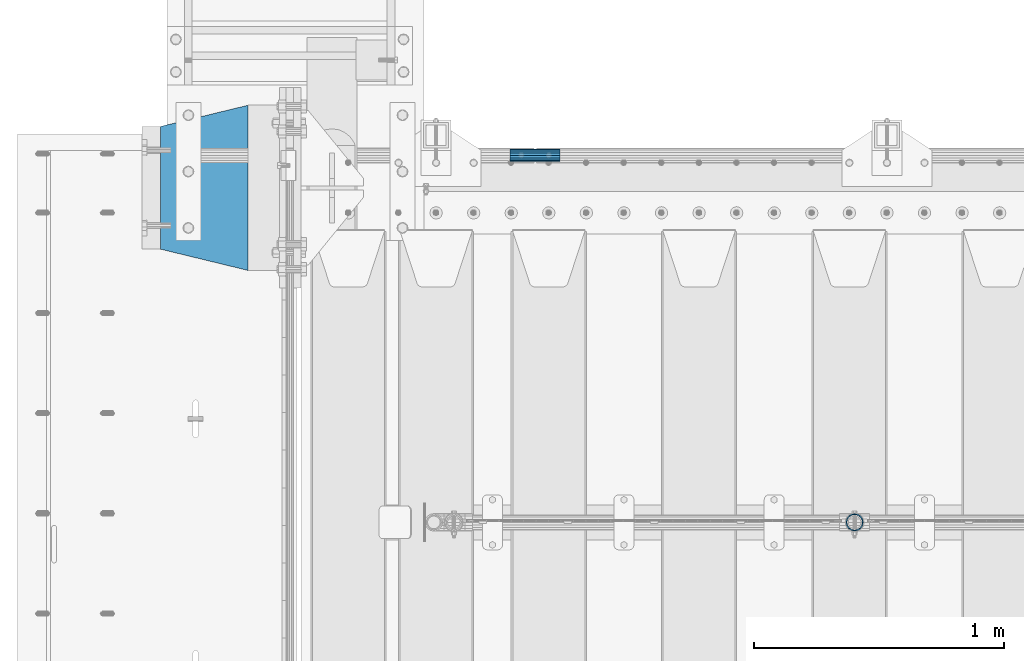
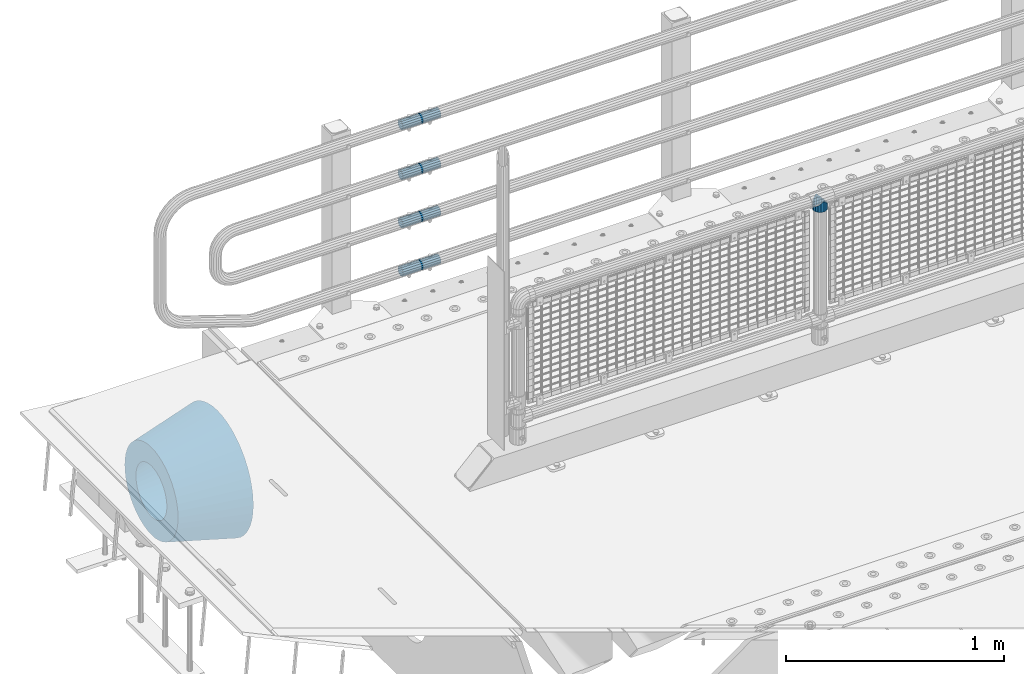
# One storey, part 148 of 247: 6 beams.
"""IFC2X3 building model written with IfcOpenShell, lengths in millimetres."""

from ifc_helpers import new_model, si_unit, frame, origin_with_axes, place, context, subcontext, project, spatial, faceted_brep, material, type_object, element, save


model = new_model("IFC2X3")

# Units and contexts
model_context = context("Model", 3, precision=1e-05, world=origin_with_axes())
body_context = subcontext(model_context, "Body", "Model", "MODEL_VIEW")
ifc_project = project(units=[si_unit("LENGTHUNIT", "METRE", prefix="MILLI"), si_unit("AREAUNIT", "SQUARE_METRE"), si_unit("VOLUMEUNIT", "CUBIC_METRE"), si_unit("MASSUNIT", "GRAM", prefix="KILO"), si_unit("TIMEUNIT", "SECOND"), si_unit("PLANEANGLEUNIT", "RADIAN"), si_unit("SOLIDANGLEUNIT", "STERADIAN"), si_unit("THERMODYNAMICTEMPERATUREUNIT", "DEGREE_CELSIUS"), si_unit("LUMINOUSINTENSITYUNIT", "LUMEN")], contexts=[model_context])

# Site, building, storey
site_placement = place(None, origin_with_axes())
site = spatial("IfcSite", under=ifc_project, at=site_placement, CompositionType="ELEMENT")
building_placement = place(site_placement, origin_with_axes())
building = spatial("IfcBuilding", under=site, at=building_placement, Name="Standard", CompositionType="ELEMENT")
storey_placement = place(building_placement, origin_with_axes())
storey = spatial("IfcBuildingStorey", under=building, at=storey_placement, Name="Undefined", CompositionType="ELEMENT", Elevation=0.0)

# Beams
ifc_material_1 = material(Name="Misc_Undefined")
beam_type_1 = type_object("IfcBeamType", PredefinedType="NOTDEFINED")
beam_1_placement = place(storey_placement, frame((2221.0, 7664.5, 969.849999999999), z_axis=(0.0, 1.0, 0.0), x_axis=(0.0, 0.0, -1.0)))
element("IfcBeam", 1, at=beam_1_placement, inside=storey, type_object=beam_type_1, material=ifc_material_1, context=body_context, shape_type="Brep", body=[
    faceted_brep([(0.0, 0.0, 35.1499999999996), (13.4513226476338, 13.4513226476329, 32.4743655677721), (13.4513226476338, -13.4513226476329, 32.4743655677721), (24.8548033587067, -16.3810424080045, -24.8548033587067), (24.8548033587067, -24.8548033587072, -24.8548033587067), (32.4743655677721, -32.4743655677717, -13.4513226476329), (32.4743655677721, -26.8123795176766, -13.4513226476329), (27.1226768591059, -21.4606908090117, -21.4606908090118), (0.0, 0.0, -35.1499999999996), (13.4513226476338, -13.4513226476329, -32.4743655677721), (13.4513226476338, 13.4513226476329, -32.4743655677721), (20.0882031229885, -11.6144421722805, -28.0397438117179), (16.6306603983739, 0.0, -30.3500000000004), (20.0882031229885, 11.6144421722805, -28.0397438117179), (24.8548033587067, 16.3810424080029, -24.8548033587067), (24.8548033587067, 24.8548033587072, -24.8548033587067), (27.1226768591059, 21.4606908090117, -21.4606908090118), (32.4743655677721, 26.8123795176755, -13.4513226476329), (32.4743655677721, 32.4743655677717, -13.4513226476329), (32.8397438117172, 28.0397438117175, -11.6144421722802), (35.1499999999996, 30.35, 0.0), (35.1499999999996, 35.15, 0.0), (32.8397438117172, 28.0397438117175, 11.6144421722802), (32.4743655677721, 26.8123795176755, 13.4513226476329), (32.4743655677721, 32.4743655677717, 13.4513226476329), (27.1226768591096, 21.4606908090117, 21.4606908090118), (24.8548033587067, 16.3810424080046, 24.8548033587067), (24.8548033587067, 24.8548033587072, 24.8548033587067), (20.0882031229812, 11.6144421722805, 28.0397438117179), (16.6306603983649, 0.0, 30.3500000000004), (20.0882031229812, -11.6144421722805, 28.0397438117179), (24.8548033587067, -16.3810424080045, 24.8548033587067), (24.8548033587067, -24.8548033587072, 24.8548033587067), (27.1226768591096, -21.4606908090117, 21.4606908090118), (32.4743655677721, -26.8123795176755, 13.4513226476329), (32.4743655677721, -32.4743655677717, 13.4513226476329), (32.8397438117172, -28.0397438117175, 11.6144421722802), (35.1499999999996, -30.35, 0.0), (35.1499999999996, -35.15, 0.0), (32.8397438117172, -28.0397438117175, -11.6144421722802), (60.1499999999996, -24.8548033587072, -24.8548033587067), (60.1499999999996, -32.4743655677717, -13.4513226476329), (60.1499999999996, -13.4513226476329, -32.4743655677721), (60.1499999999996, 0.0, -35.1499999999996), (60.1499999999996, 13.4513226476329, -32.4743655677721), (60.1499999999996, 24.8548033587072, -24.8548033587067), (60.1499999999996, 32.4743655677717, -13.4513226476329), (60.1499999999996, 35.15, 0.0), (60.1499999999996, 32.4743655677717, 13.4513226476329), (60.1499999999996, 24.8548033587072, 24.8548033587067), (60.1499999999996, 13.4513226476329, 32.4743655677721), (60.1499999999996, 0.0, 35.1499999999996), (60.1499999999996, -13.4513226476329, 32.4743655677721), (60.1499999999996, -24.8548033587072, 24.8548033587067), (60.1499999999996, -32.4743655677717, 13.4513226476329), (60.1499999999996, -35.15, 0.0), (60.1499999999996, -21.4606908090117, 21.4606908090118), (60.1499999999996, -11.6144421722805, 28.0397438117179), (60.1499999999996, 0.0, 30.3500000000004), (60.1499999999996, 11.6144421722805, 28.0397438117179), (60.1499999999996, 21.4606908090117, 21.4606908090118), (60.1499999999996, 28.0397438117175, 11.6144421722802), (60.1499999999996, 30.35, 0.0), (60.1499999999996, 28.0397438117175, -11.6144421722802), (60.1499999999996, 21.4606908090117, -21.4606908090118), (60.1499999999996, 11.6144421722805, -28.0397438117179), (60.1499999999996, 0.0, -30.3500000000004), (60.1499999999996, -11.6144421722805, -28.0397438117179), (60.1499999999996, -21.4606908090117, -21.4606908090118), (60.1499999999996, -28.0397438117175, -11.6144421722802), (60.1499999999996, -30.35, 0.0), (60.1499999999996, -28.0397438117175, 11.6144421722802)], [[[0, 1, 2]], [[3, 4, 5, 6, 7]], [[8, 9, 10]], [[10, 9, 4, 3, 11, 12, 13, 14, 15]], [[15, 14, 16, 17, 18]], [[18, 17, 19, 20, 21]], [[21, 20, 22, 23, 24]], [[24, 23, 25, 26, 27]], [[27, 26, 28, 29, 30, 31, 32, 2, 1]], [[33, 34, 35, 32, 31]], [[36, 37, 38, 35, 34]], [[6, 5, 38, 37, 39]], [[40, 41, 5, 4]], [[42, 40, 4, 9]], [[43, 42, 9, 8]], [[44, 43, 8, 10]], [[45, 44, 10, 15]], [[46, 45, 15, 18]], [[47, 46, 18, 21]], [[48, 47, 21, 24]], [[49, 48, 24, 27]], [[50, 49, 27, 1]], [[51, 50, 1, 0]], [[52, 51, 0, 2]], [[53, 52, 2, 32]], [[54, 53, 32, 35]], [[55, 54, 35, 38]], [[41, 55, 38, 5]], [[40, 42, 43, 44, 45, 46, 47, 48, 49, 50, 51, 52, 53, 54, 55, 41], [56, 57, 58, 59, 60, 61, 62, 63, 64, 65, 66, 67, 68, 69, 70, 71]], [[71, 70, 37, 36]], [[56, 71, 36, 34, 33]], [[57, 56, 33, 31, 30]], [[58, 57, 30, 29]], [[59, 58, 29, 28]], [[25, 60, 59, 28, 26]], [[22, 61, 60, 25, 23]], [[62, 61, 22, 20]], [[63, 62, 20, 19]], [[64, 63, 19, 17, 16]], [[65, 64, 16, 14, 13]], [[66, 65, 13, 12]], [[67, 66, 12, 11]], [[7, 68, 67, 11, 3]], [[39, 69, 68, 7, 6]], [[70, 69, 39, 37]]]),
])
ifc_material_2 = material()
beam_type_2 = type_object("IfcBeamType", PredefinedType="NOTDEFINED")
beam_2_placement = place(storey_placement, frame((844.997502999948, 9129.8500000004, 149.849999999725), z_axis=(0.0, 0.0, 1.0), x_axis=(1.0, 0.0, 0.0)))
element("IfcBeam", 2, at=beam_2_placement, inside=storey, type_object=beam_type_2, material=ifc_material_2, context=body_context, shape_type="Brep", body=[
    faceted_brep([(0.0, -21.8999999999996, 0.0), (0.0, -20.232961761998, 8.38076716879547), (200.0, -20.232961761998, 8.38076716879547), (200.0, -21.8999999999996, 0.0), (0.0, -15.4856385079856, 15.4856385079854), (200.0, -15.4856385079856, 15.4856385079854), (0.0, -8.3807671687955, 20.2329617619972), (200.0, -8.3807671687955, 20.2329617619972), (0.0, 0.0, 21.9), (200.0, 0.0, 21.9), (0.0, 8.3807671687955, 20.2329617619972), (200.0, 8.3807671687955, 20.2329617619972), (0.0, 15.4856385079856, 15.4856385079854), (200.0, 15.4856385079856, 15.4856385079854), (0.0, 20.232961761998, 8.38076716879547), (200.0, 20.232961761998, 8.38076716879547), (0.0, 21.8999999999996, 0.0), (200.0, 21.8999999999996, 0.0), (0.0, 20.232961761998, -8.38076716879547), (200.0, 20.232961761998, -8.38076716879547), (0.0, 15.4856385079856, -15.4856385079854), (200.0, 15.4856385079856, -15.4856385079854), (0.0, 8.3807671687955, -20.2329617619972), (200.0, 8.3807671687955, -20.2329617619972), (0.0, 0.0, -21.9), (200.0, 0.0, -21.9), (0.0, -8.3807671687955, -20.2329617619972), (200.0, -8.3807671687955, -20.2329617619972), (0.0, -15.4856385079856, -15.4856385079854), (200.0, -15.4856385079856, -15.4856385079854), (0.0, -20.232961761998, -8.38076716879547), (200.0, -20.232961761998, -8.38076716879547), (0.0, -25.5, 0.0), (0.0, -23.5589280790373, -9.7584275253098), (200.0, -23.5589280790373, -9.7584275253098), (200.0, -25.5, 0.0), (0.0, -18.0312229202573, -18.031222920257), (200.0, -18.0312229202573, -18.031222920257), (0.0, -9.75842752531025, -23.5589280790378), (200.0, -9.75842752531025, -23.5589280790378), (0.0, 0.0, -25.5), (200.0, 0.0, -25.5), (0.0, 9.75842752531025, -23.5589280790378), (200.0, 9.75842752531025, -23.5589280790378), (0.0, 18.0312229202573, -18.031222920257), (200.0, 18.0312229202573, -18.031222920257), (0.0, 23.5589280790373, -9.7584275253098), (200.0, 23.5589280790373, -9.7584275253098), (0.0, 25.5, 0.0), (200.0, 25.5, 0.0), (0.0, 23.5589280790373, 9.7584275253098), (200.0, 23.5589280790373, 9.7584275253098), (0.0, 18.0312229202573, 18.031222920257), (200.0, 18.0312229202573, 18.031222920257), (0.0, 9.75842752531025, 23.5589280790378), (200.0, 9.75842752531025, 23.5589280790378), (0.0, 0.0, 25.5), (200.0, 0.0, 25.5), (0.0, -9.75842752531025, 23.5589280790378), (200.0, -9.75842752531025, 23.5589280790378), (0.0, -18.0312229202573, 18.031222920257), (200.0, -18.0312229202573, 18.031222920257), (0.0, -23.5589280790373, 9.7584275253098), (200.0, -23.5589280790373, 9.7584275253098)], [[[0, 1, 2, 3]], [[1, 4, 5, 2]], [[4, 6, 7, 5]], [[6, 8, 9, 7]], [[8, 10, 11, 9]], [[10, 12, 13, 11]], [[12, 14, 15, 13]], [[14, 16, 17, 15]], [[16, 18, 19, 17]], [[18, 20, 21, 19]], [[20, 22, 23, 21]], [[22, 24, 25, 23]], [[24, 26, 27, 25]], [[26, 28, 29, 27]], [[28, 30, 31, 29]], [[30, 0, 3, 31]], [[32, 33, 34, 35]], [[33, 36, 37, 34]], [[36, 38, 39, 37]], [[38, 40, 41, 39]], [[40, 42, 43, 41]], [[42, 44, 45, 43]], [[44, 46, 47, 45]], [[46, 48, 49, 47]], [[48, 50, 51, 49]], [[50, 52, 53, 51]], [[52, 54, 55, 53]], [[54, 56, 57, 55]], [[56, 58, 59, 57]], [[58, 60, 61, 59]], [[60, 62, 63, 61]], [[62, 32, 35, 63]], [[37, 39, 41, 43, 45, 47, 49, 51, 53, 55, 57, 59, 61, 63, 35, 34], [5, 7, 9, 11, 13, 15, 17, 19, 21, 23, 25, 27, 29, 31, 3, 2]], [[62, 60, 58, 56, 54, 52, 50, 48, 46, 44, 42, 40, 38, 36, 33, 32], [30, 28, 26, 24, 22, 20, 18, 16, 14, 12, 10, 8, 6, 4, 1, 0]]]),
])
beam_3_placement = place(storey_placement, frame((844.997502999948, 9129.8500000004, 420.149999999724), z_axis=(0.0, 0.0, 1.0), x_axis=(1.0, 0.0, 0.0)))
element("IfcBeam", 3, at=beam_3_placement, inside=storey, type_object=beam_type_2, material=ifc_material_2, context=body_context, shape_type="Brep", body=[
    faceted_brep([(0.0, -21.8999999999996, 0.0), (0.0, -20.232961761998, 8.38076716879547), (200.0, -20.232961761998, 8.38076716879547), (200.0, -21.8999999999996, 0.0), (0.0, -15.4856385079856, 15.4856385079854), (200.0, -15.4856385079856, 15.4856385079854), (0.0, -8.3807671687955, 20.2329617619972), (200.0, -8.3807671687955, 20.2329617619972), (0.0, 0.0, 21.9), (200.0, 0.0, 21.9), (0.0, 8.3807671687955, 20.2329617619972), (200.0, 8.3807671687955, 20.2329617619972), (0.0, 15.4856385079856, 15.4856385079854), (200.0, 15.4856385079856, 15.4856385079854), (0.0, 20.232961761998, 8.38076716879547), (200.0, 20.232961761998, 8.38076716879547), (0.0, 21.8999999999996, 0.0), (200.0, 21.8999999999996, 0.0), (0.0, 20.232961761998, -8.38076716879547), (200.0, 20.232961761998, -8.38076716879547), (0.0, 15.4856385079856, -15.4856385079854), (200.0, 15.4856385079856, -15.4856385079854), (0.0, 8.3807671687955, -20.2329617619972), (200.0, 8.3807671687955, -20.2329617619972), (0.0, 0.0, -21.9), (200.0, 0.0, -21.9), (0.0, -8.3807671687955, -20.2329617619972), (200.0, -8.3807671687955, -20.2329617619972), (0.0, -15.4856385079856, -15.4856385079854), (200.0, -15.4856385079856, -15.4856385079854), (0.0, -20.232961761998, -8.38076716879547), (200.0, -20.232961761998, -8.38076716879547), (0.0, -25.5, 0.0), (0.0, -23.5589280790373, -9.7584275253098), (200.0, -23.5589280790373, -9.7584275253098), (200.0, -25.5, 0.0), (0.0, -18.0312229202573, -18.031222920257), (200.0, -18.0312229202573, -18.031222920257), (0.0, -9.75842752531025, -23.5589280790378), (200.0, -9.75842752531025, -23.5589280790378), (0.0, 0.0, -25.5), (200.0, 0.0, -25.5), (0.0, 9.75842752531025, -23.5589280790378), (200.0, 9.75842752531025, -23.5589280790378), (0.0, 18.0312229202573, -18.031222920257), (200.0, 18.0312229202573, -18.031222920257), (0.0, 23.5589280790373, -9.7584275253098), (200.0, 23.5589280790373, -9.7584275253098), (0.0, 25.5, 0.0), (200.0, 25.5, 0.0), (0.0, 23.5589280790373, 9.7584275253098), (200.0, 23.5589280790373, 9.7584275253098), (0.0, 18.0312229202573, 18.031222920257), (200.0, 18.0312229202573, 18.031222920257), (0.0, 9.75842752531025, 23.5589280790378), (200.0, 9.75842752531025, 23.5589280790378), (0.0, 0.0, 25.5), (200.0, 0.0, 25.5), (0.0, -9.75842752531025, 23.5589280790378), (200.0, -9.75842752531025, 23.5589280790378), (0.0, -18.0312229202573, 18.031222920257), (200.0, -18.0312229202573, 18.031222920257), (0.0, -23.5589280790373, 9.7584275253098), (200.0, -23.5589280790373, 9.7584275253098)], [[[0, 1, 2, 3]], [[1, 4, 5, 2]], [[4, 6, 7, 5]], [[6, 8, 9, 7]], [[8, 10, 11, 9]], [[10, 12, 13, 11]], [[12, 14, 15, 13]], [[14, 16, 17, 15]], [[16, 18, 19, 17]], [[18, 20, 21, 19]], [[20, 22, 23, 21]], [[22, 24, 25, 23]], [[24, 26, 27, 25]], [[26, 28, 29, 27]], [[28, 30, 31, 29]], [[30, 0, 3, 31]], [[32, 33, 34, 35]], [[33, 36, 37, 34]], [[36, 38, 39, 37]], [[38, 40, 41, 39]], [[40, 42, 43, 41]], [[42, 44, 45, 43]], [[44, 46, 47, 45]], [[46, 48, 49, 47]], [[48, 50, 51, 49]], [[50, 52, 53, 51]], [[52, 54, 55, 53]], [[54, 56, 57, 55]], [[56, 58, 59, 57]], [[58, 60, 61, 59]], [[60, 62, 63, 61]], [[62, 32, 35, 63]], [[37, 39, 41, 43, 45, 47, 49, 51, 53, 55, 57, 59, 61, 63, 35, 34], [5, 7, 9, 11, 13, 15, 17, 19, 21, 23, 25, 27, 29, 31, 3, 2]], [[62, 60, 58, 56, 54, 52, 50, 48, 46, 44, 42, 40, 38, 36, 33, 32], [30, 28, 26, 24, 22, 20, 18, 16, 14, 12, 10, 8, 6, 4, 1, 0]]]),
])
beam_4_placement = place(storey_placement, frame((844.997502999948, 9129.8500000004, 969.849999999725), z_axis=(0.0, 0.0, 1.0), x_axis=(1.0, 0.0, 0.0)))
element("IfcBeam", 4, at=beam_4_placement, inside=storey, type_object=beam_type_2, material=ifc_material_2, context=body_context, shape_type="Brep", body=[
    faceted_brep([(0.0, -21.8999999999996, 0.0), (0.0, -20.232961761998, 8.38076716879547), (200.0, -20.232961761998, 8.38076716879547), (200.0, -21.8999999999996, 0.0), (0.0, -15.4856385079856, 15.4856385079854), (200.0, -15.4856385079856, 15.4856385079854), (0.0, -8.3807671687955, 20.2329617619972), (200.0, -8.3807671687955, 20.2329617619972), (0.0, 0.0, 21.9), (200.0, 0.0, 21.9), (0.0, 8.3807671687955, 20.2329617619972), (200.0, 8.3807671687955, 20.2329617619972), (0.0, 15.4856385079856, 15.4856385079854), (200.0, 15.4856385079856, 15.4856385079854), (0.0, 20.232961761998, 8.38076716879547), (200.0, 20.232961761998, 8.38076716879547), (0.0, 21.8999999999996, 0.0), (200.0, 21.8999999999996, 0.0), (0.0, 20.232961761998, -8.38076716879547), (200.0, 20.232961761998, -8.38076716879547), (0.0, 15.4856385079856, -15.4856385079854), (200.0, 15.4856385079856, -15.4856385079854), (0.0, 8.3807671687955, -20.2329617619972), (200.0, 8.3807671687955, -20.2329617619972), (0.0, 0.0, -21.9), (200.0, 0.0, -21.9), (0.0, -8.3807671687955, -20.2329617619972), (200.0, -8.3807671687955, -20.2329617619972), (0.0, -15.4856385079856, -15.4856385079854), (200.0, -15.4856385079856, -15.4856385079854), (0.0, -20.232961761998, -8.38076716879547), (200.0, -20.232961761998, -8.38076716879547), (0.0, -25.5, 0.0), (0.0, -23.5589280790373, -9.7584275253098), (200.0, -23.5589280790373, -9.7584275253098), (200.0, -25.5, 0.0), (0.0, -18.0312229202573, -18.031222920257), (200.0, -18.0312229202573, -18.031222920257), (0.0, -9.75842752531025, -23.5589280790378), (200.0, -9.75842752531025, -23.5589280790378), (0.0, 0.0, -25.5), (200.0, 0.0, -25.5), (0.0, 9.75842752531025, -23.5589280790378), (200.0, 9.75842752531025, -23.5589280790378), (0.0, 18.0312229202573, -18.031222920257), (200.0, 18.0312229202573, -18.031222920257), (0.0, 23.5589280790373, -9.7584275253098), (200.0, 23.5589280790373, -9.7584275253098), (0.0, 25.5, 0.0), (200.0, 25.5, 0.0), (0.0, 23.5589280790373, 9.7584275253098), (200.0, 23.5589280790373, 9.7584275253098), (0.0, 18.0312229202573, 18.031222920257), (200.0, 18.0312229202573, 18.031222920257), (0.0, 9.75842752531025, 23.5589280790378), (200.0, 9.75842752531025, 23.5589280790378), (0.0, 0.0, 25.5), (200.0, 0.0, 25.5), (0.0, -9.75842752531025, 23.5589280790378), (200.0, -9.75842752531025, 23.5589280790378), (0.0, -18.0312229202573, 18.031222920257), (200.0, -18.0312229202573, 18.031222920257), (0.0, -23.5589280790373, 9.7584275253098), (200.0, -23.5589280790373, 9.7584275253098)], [[[0, 1, 2, 3]], [[1, 4, 5, 2]], [[4, 6, 7, 5]], [[6, 8, 9, 7]], [[8, 10, 11, 9]], [[10, 12, 13, 11]], [[12, 14, 15, 13]], [[14, 16, 17, 15]], [[16, 18, 19, 17]], [[18, 20, 21, 19]], [[20, 22, 23, 21]], [[22, 24, 25, 23]], [[24, 26, 27, 25]], [[26, 28, 29, 27]], [[28, 30, 31, 29]], [[30, 0, 3, 31]], [[32, 33, 34, 35]], [[33, 36, 37, 34]], [[36, 38, 39, 37]], [[38, 40, 41, 39]], [[40, 42, 43, 41]], [[42, 44, 45, 43]], [[44, 46, 47, 45]], [[46, 48, 49, 47]], [[48, 50, 51, 49]], [[50, 52, 53, 51]], [[52, 54, 55, 53]], [[54, 56, 57, 55]], [[56, 58, 59, 57]], [[58, 60, 61, 59]], [[60, 62, 63, 61]], [[62, 32, 35, 63]], [[37, 39, 41, 43, 45, 47, 49, 51, 53, 55, 57, 59, 61, 63, 35, 34], [5, 7, 9, 11, 13, 15, 17, 19, 21, 23, 25, 27, 29, 31, 3, 2]], [[62, 60, 58, 56, 54, 52, 50, 48, 46, 44, 42, 40, 38, 36, 33, 32], [30, 28, 26, 24, 22, 20, 18, 16, 14, 12, 10, 8, 6, 4, 1, 0]]]),
])
beam_5_placement = place(storey_placement, frame((844.997502999948, 9129.8500000004, 689.849999999725), z_axis=(0.0, 0.0, 1.0), x_axis=(1.0, 0.0, 0.0)))
element("IfcBeam", 5, at=beam_5_placement, inside=storey, type_object=beam_type_2, material=ifc_material_2, context=body_context, shape_type="Brep", body=[
    faceted_brep([(0.0, -21.8999999999996, 0.0), (0.0, -20.232961761998, 8.38076716879547), (200.0, -20.232961761998, 8.38076716879547), (200.0, -21.8999999999996, 0.0), (0.0, -15.4856385079856, 15.4856385079854), (200.0, -15.4856385079856, 15.4856385079854), (0.0, -8.3807671687955, 20.2329617619972), (200.0, -8.3807671687955, 20.2329617619972), (0.0, 0.0, 21.9), (200.0, 0.0, 21.9), (0.0, 8.3807671687955, 20.2329617619972), (200.0, 8.3807671687955, 20.2329617619972), (0.0, 15.4856385079856, 15.4856385079854), (200.0, 15.4856385079856, 15.4856385079854), (0.0, 20.232961761998, 8.38076716879547), (200.0, 20.232961761998, 8.38076716879547), (0.0, 21.8999999999996, 0.0), (200.0, 21.8999999999996, 0.0), (0.0, 20.232961761998, -8.38076716879547), (200.0, 20.232961761998, -8.38076716879547), (0.0, 15.4856385079856, -15.4856385079854), (200.0, 15.4856385079856, -15.4856385079854), (0.0, 8.3807671687955, -20.2329617619972), (200.0, 8.3807671687955, -20.2329617619972), (0.0, 0.0, -21.9), (200.0, 0.0, -21.9), (0.0, -8.3807671687955, -20.2329617619972), (200.0, -8.3807671687955, -20.2329617619972), (0.0, -15.4856385079856, -15.4856385079854), (200.0, -15.4856385079856, -15.4856385079854), (0.0, -20.232961761998, -8.38076716879547), (200.0, -20.232961761998, -8.38076716879547), (0.0, -25.5, 0.0), (0.0, -23.5589280790373, -9.7584275253098), (200.0, -23.5589280790373, -9.7584275253098), (200.0, -25.5, 0.0), (0.0, -18.0312229202573, -18.031222920257), (200.0, -18.0312229202573, -18.031222920257), (0.0, -9.75842752531025, -23.5589280790378), (200.0, -9.75842752531025, -23.5589280790378), (0.0, 0.0, -25.5), (200.0, 0.0, -25.5), (0.0, 9.75842752531025, -23.5589280790378), (200.0, 9.75842752531025, -23.5589280790378), (0.0, 18.0312229202573, -18.031222920257), (200.0, 18.0312229202573, -18.031222920257), (0.0, 23.5589280790373, -9.7584275253098), (200.0, 23.5589280790373, -9.7584275253098), (0.0, 25.5, 0.0), (200.0, 25.5, 0.0), (0.0, 23.5589280790373, 9.7584275253098), (200.0, 23.5589280790373, 9.7584275253098), (0.0, 18.0312229202573, 18.031222920257), (200.0, 18.0312229202573, 18.031222920257), (0.0, 9.75842752531025, 23.5589280790378), (200.0, 9.75842752531025, 23.5589280790378), (0.0, 0.0, 25.5), (200.0, 0.0, 25.5), (0.0, -9.75842752531025, 23.5589280790378), (200.0, -9.75842752531025, 23.5589280790378), (0.0, -18.0312229202573, 18.031222920257), (200.0, -18.0312229202573, 18.031222920257), (0.0, -23.5589280790373, 9.7584275253098), (200.0, -23.5589280790373, 9.7584275253098)], [[[0, 1, 2, 3]], [[1, 4, 5, 2]], [[4, 6, 7, 5]], [[6, 8, 9, 7]], [[8, 10, 11, 9]], [[10, 12, 13, 11]], [[12, 14, 15, 13]], [[14, 16, 17, 15]], [[16, 18, 19, 17]], [[18, 20, 21, 19]], [[20, 22, 23, 21]], [[22, 24, 25, 23]], [[24, 26, 27, 25]], [[26, 28, 29, 27]], [[28, 30, 31, 29]], [[30, 0, 3, 31]], [[32, 33, 34, 35]], [[33, 36, 37, 34]], [[36, 38, 39, 37]], [[38, 40, 41, 39]], [[40, 42, 43, 41]], [[42, 44, 45, 43]], [[44, 46, 47, 45]], [[46, 48, 49, 47]], [[48, 50, 51, 49]], [[50, 52, 53, 51]], [[52, 54, 55, 53]], [[54, 56, 57, 55]], [[56, 58, 59, 57]], [[58, 60, 61, 59]], [[60, 62, 63, 61]], [[62, 32, 35, 63]], [[37, 39, 41, 43, 45, 47, 49, 51, 53, 55, 57, 59, 61, 63, 35, 34], [5, 7, 9, 11, 13, 15, 17, 19, 21, 23, 25, 27, 29, 31, 3, 2]], [[62, 60, 58, 56, 54, 52, 50, 48, 46, 44, 42, 40, 38, 36, 33, 32], [30, 28, 26, 24, 22, 20, 18, 16, 14, 12, 10, 8, 6, 4, 1, 0]]]),
])
ifc_material_3 = material(Name="SCN-500-E2")
beam_type_3 = type_object("IfcBeamType", PredefinedType="NOTDEFINED")
beam_6_placement = place(storey_placement, frame((-199.999999999991, 9000.0, -515.0), z_axis=(0.0, 0.0, 1.0), x_axis=(-1.0, 0.0, 0.0)))
element("IfcBeam", 6, at=beam_6_placement, inside=storey, type_object=beam_type_3, material=ifc_material_3, context=body_context, shape_type="Brep", body=[
    faceted_brep([(0.0, -330.0, 0.0), (0.0, -326.641075820708, -46.9638966301842), (350.0, -242.506253260828, -34.8671353769549), (350.0, -245.0, 0.0), (0.0, -316.632681292784, -92.9717437576718), (350.0, -235.075778535553, -69.0244764261503), (0.0, -300.178558466991, -137.086954290623), (350.0, -222.859838861858, -101.776678185462), (0.0, -277.613665834289, -178.411469760347), (350.0, -206.10711554364, -132.457000276621), (0.0, -249.397359536906, -216.104042201944), (350.0, -185.158645716794, -160.440879816595), (0.0, -216.104042201943, -249.397359536905), (350.0, -160.440879816595, -185.158645716793), (0.0, -178.411469760347, -277.61366583429), (350.0, -132.457000276621, -206.107115543639), (0.0, -137.086954290622, -300.178558466991), (350.0, -101.776678185463, -222.859838861857), (0.0, -92.971743757671, -316.632681292784), (350.0, -69.0244764261497, -235.075778535552), (0.0, -46.9638966301845, -326.641075820708), (350.0, -34.867135376955, -242.506253260829), (0.0, 0.0, -330.0), (350.0, 0.0, -245.0), (0.0, 46.9638966301845, -326.641075820708), (350.0, 34.867135376955, -242.506253260829), (0.0, 92.971743757671, -316.632681292784), (350.0, 69.0244764261497, -235.075778535552), (0.0, 137.086954290622, -300.178558466991), (350.0, 101.776678185463, -222.859838861857), (0.0, 178.411469760347, -277.61366583429), (350.0, 132.457000276621, -206.107115543639), (0.0, 216.104042201943, -249.397359536905), (350.0, 160.440879816595, -185.158645716793), (0.0, 249.397359536906, -216.104042201944), (350.0, 185.158645716794, -160.440879816595), (0.0, 277.613665834289, -178.411469760347), (350.0, 206.10711554364, -132.457000276621), (0.0, 300.178558466991, -137.086954290623), (350.0, 222.859838861858, -101.776678185462), (0.0, 316.632681292784, -92.9717437576717), (350.0, 235.075778535553, -69.0244764261502), (0.0, 326.641075820708, -46.9638966301841), (350.0, 242.506253260828, -34.8671353769548), (0.0, 330.0, 0.0), (350.0, 245.0, 0.0), (0.0, 326.641075820708, 46.9638966301841), (350.0, 242.506253260828, 34.8671353769549), (0.0, 316.632681292784, 92.9717437576718), (350.0, 235.075778535553, 69.0244764261503), (0.0, 300.178558466991, 137.086954290622), (350.0, 222.859838861858, 101.776678185462), (0.0, 277.613665834289, 178.411469760347), (350.0, 206.10711554364, 132.457000276621), (0.0, 249.397359536904, 216.104042201944), (350.0, 185.158645716794, 160.440879816595), (0.0, 216.104042201943, 249.397359536905), (350.0, 160.440879816595, 185.158645716793), (0.0, 178.411469760347, 277.61366583429), (350.0, 132.457000276621, 206.107115543639), (0.0, 137.086954290622, 300.178558466991), (350.0, 101.776678185463, 222.859838861857), (0.0, 92.971743757671, 316.632681292784), (350.0, 69.0244764261497, 235.075778535552), (0.0, 46.9638966301845, 326.641075820708), (350.0, 34.867135376955, 242.506253260829), (0.0, 0.0, 330.0), (350.0, 0.0, 245.0), (0.0, -46.9638966301845, 326.641075820708), (350.0, -34.867135376955, 242.506253260829), (0.0, -92.971743757671, 316.632681292784), (350.0, -69.0244764261497, 235.075778535552), (0.0, -137.086954290622, 300.178558466991), (350.0, -101.776678185463, 222.859838861857), (0.0, -178.411469760347, 277.61366583429), (350.0, -132.457000276621, 206.107115543639), (0.0, -216.104042201943, 249.397359536905), (350.0, -160.440879816595, 185.158645716793), (0.0, -249.397359536906, 216.104042201944), (350.0, -185.158645716794, 160.440879816595), (0.0, -277.613665834289, 178.411469760347), (350.0, -206.10711554364, 132.457000276621), (0.0, -300.178558466991, 137.086954290623), (350.0, -222.859838861858, 101.776678185462), (0.0, -316.632681292784, 92.9717437576718), (350.0, -235.075778535553, 69.0244764261503), (0.0, -326.641075820708, 46.9638966301841), (350.0, -242.506253260828, 34.8671353769549), (0.0, -227.093265923131, 0.0), (0.0, -224.781783917484, 32.3187414128026), (350.0, -140.646961357605, 20.2219801595734), (350.0, -142.093265923131, 0.0), (0.0, -217.894393008413, 63.9795664499945), (350.0, -136.337490251181, 40.032299118473), (0.0, -206.571300613232, 94.3379520160985), (350.0, -129.252581008099, 59.0276759109381), (0.0, -191.043012240005, 122.775888927343), (350.0, -119.536461949354, 76.8214194436173), (0.0, -171.625639060125, 148.714462796454), (350.0, -107.386925240013, 93.0513004111044), (0.0, -148.714462796454, 171.625639060125), (350.0, -93.0513004111053, 107.386925240013), (0.0, -122.775888927343, 191.043012240005), (350.0, -76.8214194436168, 119.536461949355), (0.0, -94.3379520160979, 206.571300613232), (350.0, -59.0276759109383, 129.252581008098), (0.0, -63.9795664499943, 217.894393008413), (350.0, -40.032299118473, 136.337490251181), (0.0, -32.3187414128024, 224.781783917484), (350.0, -20.2219801595729, 140.646961357605), (0.0, 0.0, 227.093265923131), (350.0, 0.0, 142.093265923131), (0.0, 32.3187414128024, 224.781783917484), (350.0, 20.2219801595729, 140.646961357605), (0.0, 63.9795664499943, 217.894393008413), (350.0, 40.032299118473, 136.337490251181), (0.0, 94.3379520160979, 206.571300613232), (350.0, 59.0276759109383, 129.252581008098), (0.0, 122.775888927343, 191.043012240005), (350.0, 76.8214194436168, 119.536461949355), (0.0, 148.714462796454, 171.625639060125), (350.0, 93.0513004111053, 107.386925240013), (0.0, 171.625639060125, 148.714462796454), (350.0, 107.386925240013, 93.0513004111044), (0.0, 191.043012240005, 122.775888927343), (350.0, 119.536461949354, 76.8214194436174), (0.0, 206.571300613232, 94.3379520160985), (350.0, 129.252581008099, 59.0276759109382), (0.0, 217.894393008413, 63.9795664499945), (350.0, 136.337490251181, 40.032299118473), (0.0, 224.781783917484, 32.3187414128025), (350.0, 140.646961357605, 20.2219801595733), (0.0, 227.093265923131, 0.0), (350.0, 142.093265923131, 0.0), (0.0, 224.781783917484, -32.3187414128026), (350.0, 140.646961357605, -20.2219801595734), (0.0, 217.894393008413, -63.9795664499945), (350.0, 136.337490251181, -40.032299118473), (0.0, 206.571300613232, -94.3379520160985), (350.0, 129.252581008099, -59.0276759109381), (0.0, 191.043012240005, -122.775888927343), (350.0, 119.536461949354, -76.8214194436174), (0.0, 171.625639060125, -148.714462796454), (350.0, 107.386925240013, -93.0513004111044), (0.0, 148.714462796454, -171.625639060125), (350.0, 93.0513004111035, -107.386925240013), (0.0, 122.775888927343, -191.043012240005), (350.0, 76.8214194436168, -119.536461949355), (0.0, 94.3379520160979, -206.571300613232), (350.0, 59.0276759109383, -129.252581008098), (0.0, 63.9795664499943, -217.894393008413), (350.0, 40.032299118473, -136.337490251181), (0.0, 32.3187414128024, -224.781783917484), (350.0, 20.2219801595729, -140.646961357605), (0.0, 0.0, -227.093265923131), (350.0, 0.0, -142.093265923131), (0.0, -32.3187414128024, -224.781783917484), (350.0, -20.2219801595729, -140.646961357605), (0.0, -63.9795664499943, -217.894393008413), (350.0, -40.032299118473, -136.337490251181), (0.0, -94.3379520160979, -206.571300613232), (350.0, -59.0276759109383, -129.252581008098), (0.0, -122.775888927343, -191.043012240005), (350.0, -76.8214194436168, -119.536461949355), (0.0, -148.714462796454, -171.625639060125), (350.0, -93.0513004111035, -107.386925240013), (0.0, -171.625639060125, -148.714462796454), (350.0, -107.386925240013, -93.0513004111044), (0.0, -191.043012240005, -122.775888927343), (350.0, -119.536461949354, -76.8214194436174), (0.0, -206.571300613232, -94.3379520160985), (350.0, -129.252581008099, -59.0276759109381), (0.0, -217.894393008413, -63.9795664499945), (350.0, -136.337490251181, -40.032299118473), (0.0, -224.781783917484, -32.3187414128026), (350.0, -140.646961357605, -20.2219801595734)], [[[0, 1, 2, 3]], [[1, 4, 5, 2]], [[4, 6, 7, 5]], [[6, 8, 9, 7]], [[8, 10, 11, 9]], [[10, 12, 13, 11]], [[12, 14, 15, 13]], [[14, 16, 17, 15]], [[16, 18, 19, 17]], [[18, 20, 21, 19]], [[20, 22, 23, 21]], [[22, 24, 25, 23]], [[24, 26, 27, 25]], [[26, 28, 29, 27]], [[28, 30, 31, 29]], [[30, 32, 33, 31]], [[32, 34, 35, 33]], [[34, 36, 37, 35]], [[36, 38, 39, 37]], [[38, 40, 41, 39]], [[40, 42, 43, 41]], [[42, 44, 45, 43]], [[44, 46, 47, 45]], [[46, 48, 49, 47]], [[48, 50, 51, 49]], [[50, 52, 53, 51]], [[52, 54, 55, 53]], [[54, 56, 57, 55]], [[56, 58, 59, 57]], [[58, 60, 61, 59]], [[60, 62, 63, 61]], [[62, 64, 65, 63]], [[64, 66, 67, 65]], [[66, 68, 69, 67]], [[68, 70, 71, 69]], [[70, 72, 73, 71]], [[72, 74, 75, 73]], [[74, 76, 77, 75]], [[76, 78, 79, 77]], [[78, 80, 81, 79]], [[80, 82, 83, 81]], [[82, 84, 85, 83]], [[84, 86, 87, 85]], [[86, 0, 3, 87]], [[88, 89, 90, 91]], [[89, 92, 93, 90]], [[92, 94, 95, 93]], [[94, 96, 97, 95]], [[96, 98, 99, 97]], [[98, 100, 101, 99]], [[100, 102, 103, 101]], [[102, 104, 105, 103]], [[104, 106, 107, 105]], [[106, 108, 109, 107]], [[108, 110, 111, 109]], [[110, 112, 113, 111]], [[112, 114, 115, 113]], [[114, 116, 117, 115]], [[116, 118, 119, 117]], [[118, 120, 121, 119]], [[120, 122, 123, 121]], [[122, 124, 125, 123]], [[124, 126, 127, 125]], [[126, 128, 129, 127]], [[128, 130, 131, 129]], [[130, 132, 133, 131]], [[132, 134, 135, 133]], [[134, 136, 137, 135]], [[136, 138, 139, 137]], [[138, 140, 141, 139]], [[140, 142, 143, 141]], [[142, 144, 145, 143]], [[144, 146, 147, 145]], [[146, 148, 149, 147]], [[148, 150, 151, 149]], [[150, 152, 153, 151]], [[152, 154, 155, 153]], [[154, 156, 157, 155]], [[156, 158, 159, 157]], [[158, 160, 161, 159]], [[160, 162, 163, 161]], [[162, 164, 165, 163]], [[164, 166, 167, 165]], [[166, 168, 169, 167]], [[168, 170, 171, 169]], [[170, 172, 173, 171]], [[172, 174, 175, 173]], [[174, 88, 91, 175]], [[5, 7, 9, 11, 13, 15, 17, 19, 21, 23, 25, 27, 29, 31, 33, 35, 37, 39, 41, 43, 45, 47, 49, 51, 53, 55, 57, 59, 61, 63, 65, 67, 69, 71, 73, 75, 77, 79, 81, 83, 85, 87, 3, 2], [93, 95, 97, 99, 101, 103, 105, 107, 109, 111, 113, 115, 117, 119, 121, 123, 125, 127, 129, 131, 133, 135, 137, 139, 141, 143, 145, 147, 149, 151, 153, 155, 157, 159, 161, 163, 165, 167, 169, 171, 173, 175, 91, 90]], [[86, 84, 82, 80, 78, 76, 74, 72, 70, 68, 66, 64, 62, 60, 58, 56, 54, 52, 50, 48, 46, 44, 42, 40, 38, 36, 34, 32, 30, 28, 26, 24, 22, 20, 18, 16, 14, 12, 10, 8, 6, 4, 1, 0], [174, 172, 170, 168, 166, 164, 162, 160, 158, 156, 154, 152, 150, 148, 146, 144, 142, 140, 138, 136, 134, 132, 130, 128, 126, 124, 122, 120, 118, 116, 114, 112, 110, 108, 106, 104, 102, 100, 98, 96, 94, 92, 89, 88]]]),
])

save(model, "model.ifc")
